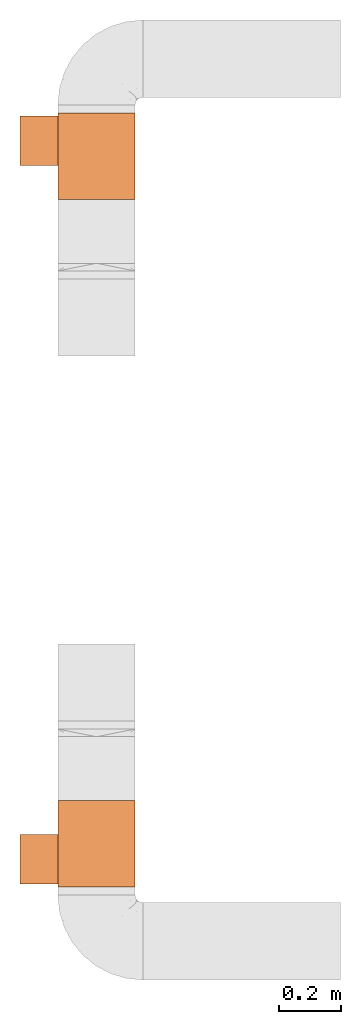
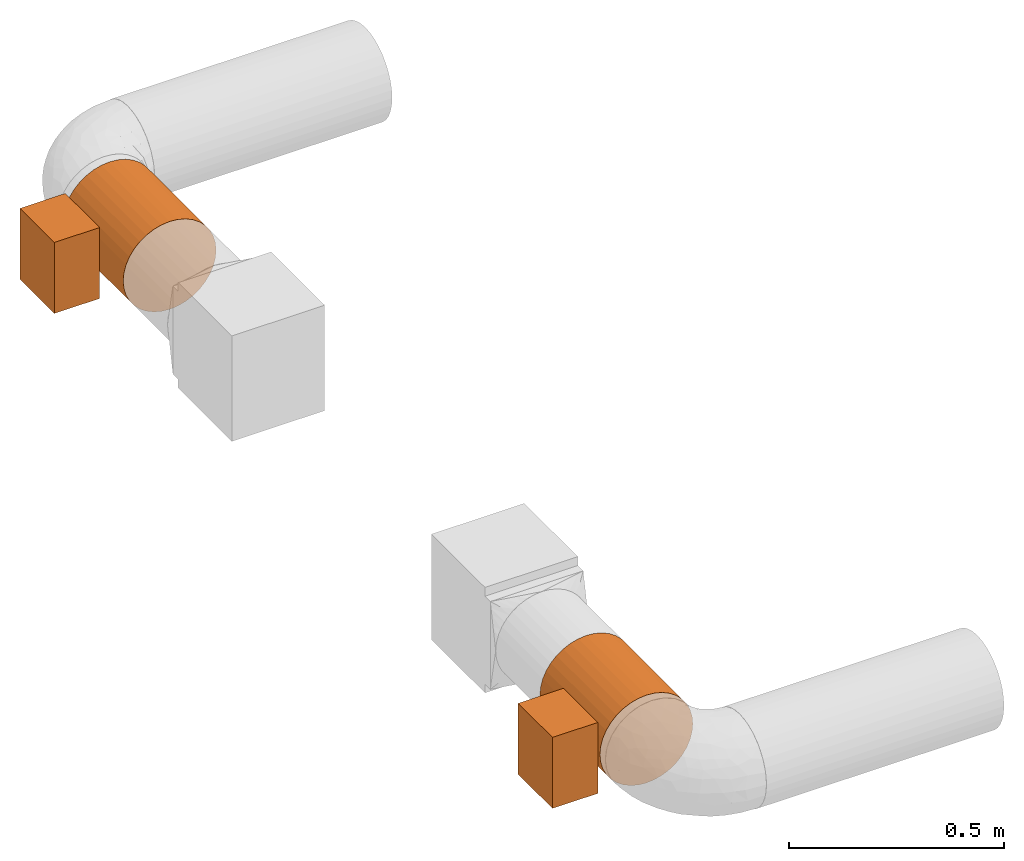
# One storey, part 4 of 4: 2 proxies.
"""IFC2X3 building model written with IfcOpenShell, lengths in millimetres."""

from ifc_helpers import new_model, entity, si_unit, converted_unit, derived_unit, direction, frame, frame_2d, origin, origin_2d_with_axis, place, context, subcontext, project, spatial, rectangle, circle, extrude, source, transform, mapped, type_object, type_shapes, element, save


model = new_model("IFC2X3")

# Units and contexts
model_context = context("Model", 3, precision=0.01, world=origin(), true_north=direction((6.12303176911189e-17, 1.0)))
body_context = subcontext(model_context, "Body", "Model", "MODEL_VIEW")
ifc_project = project(units=[si_unit("LENGTHUNIT", "METRE", prefix="MILLI"), si_unit("AREAUNIT", "SQUARE_METRE"), si_unit("VOLUMEUNIT", "CUBIC_METRE"), converted_unit("PLANEANGLEUNIT", "DEGREE", entity("IfcRatioMeasure", 0.0174532925199433), si_unit("PLANEANGLEUNIT", "RADIAN"), dimensions=[0, 0, 0, 0, 0, 0, 0]), si_unit("MASSUNIT", "GRAM", prefix="KILO"), derived_unit("MASSDENSITYUNIT", [(si_unit("MASSUNIT", "GRAM", prefix="KILO"), 1), (si_unit("LENGTHUNIT", "METRE"), -3)]), si_unit("TIMEUNIT", "SECOND"), si_unit("FREQUENCYUNIT", "HERTZ"), si_unit("THERMODYNAMICTEMPERATUREUNIT", "DEGREE_CELSIUS"), derived_unit("THERMALTRANSMITTANCEUNIT", [(si_unit("MASSUNIT", "GRAM", prefix="KILO"), 1), (si_unit("THERMODYNAMICTEMPERATUREUNIT", "KELVIN"), -1), (si_unit("TIMEUNIT", "SECOND"), -3)]), derived_unit("VOLUMETRICFLOWRATEUNIT", [(si_unit("LENGTHUNIT", "METRE"), 3), (si_unit("TIMEUNIT", "SECOND"), -1)]), si_unit("ELECTRICCURRENTUNIT", "AMPERE"), si_unit("ELECTRICVOLTAGEUNIT", "VOLT"), si_unit("POWERUNIT", "WATT"), si_unit("FORCEUNIT", "NEWTON", prefix="KILO"), si_unit("ILLUMINANCEUNIT", "LUX"), si_unit("LUMINOUSFLUXUNIT", "LUMEN"), si_unit("LUMINOUSINTENSITYUNIT", "CANDELA"), derived_unit("USERDEFINED", [(si_unit("MASSUNIT", "GRAM", prefix="KILO"), -1), (si_unit("LENGTHUNIT", "METRE"), -2), (si_unit("TIMEUNIT", "SECOND"), 3), (si_unit("LUMINOUSFLUXUNIT", "LUMEN"), 1)]), derived_unit("LINEARVELOCITYUNIT", [(si_unit("LENGTHUNIT", "METRE"), 1), (si_unit("TIMEUNIT", "SECOND"), -1)]), si_unit("PRESSUREUNIT", "PASCAL"), derived_unit("USERDEFINED", [(si_unit("LENGTHUNIT", "METRE"), -2), (si_unit("MASSUNIT", "GRAM", prefix="KILO"), 1), (si_unit("TIMEUNIT", "SECOND"), -2)])], contexts=[model_context])

# Site, building, storey
site_placement = place(None, origin())
site = spatial("IfcSite", under=ifc_project, at=site_placement, CompositionType="ELEMENT")
building_placement = place(site_placement, origin())
building = spatial("IfcBuilding", under=site, at=building_placement, CompositionType="ELEMENT")
storey_placement = place(building_placement, frame((0.0, 0.0, 8000.0)))
storey = spatial("IfcBuildingStorey", under=building, at=storey_placement, Name="02 Level", CompositionType="ELEMENT", Elevation=8000.0)

# Proxies
building_element_proxy_type_1 = type_object("IfcBuildingElementProxyType", Name="WH25-250-1", PredefinedType="NOTDEFINED")
shared_shape_1 = source(origin(), body_context, "Body", "SweptSolid", [
    extrude(rectangle(XDim=202.0, YDim=160.0, at=origin_2d_with_axis()), frame((50.0, -16.0, 125.0), z_axis=(0.0, 0.0, 1.0), x_axis=(0.0, -1.0, 0.0)), (0.0, 0.0, 1.0), 122.0),
    extrude(circle(Radius=125.0, at=frame_2d((0.0, -2.01943071804073e-13), x_axis=(1.0, 0.0))), frame((-140.0, 0.0, 0.0), z_axis=(1.0, 0.0, 0.0), x_axis=(0.0, 1.0, 0.0)), (0.0, 0.0, 1.0), 280.0),
])
type_shapes(building_element_proxy_type_1, [shared_shape_1])
proxy_1_placement = place(storey_placement, frame((25195.9632723171, -69942.4616421939, 3510.0), z_axis=(-1.0, 0.0, 0.0), x_axis=(0.0, -1.0, 0.0)))
element("IfcBuildingElementProxy", 1, at=proxy_1_placement, inside=storey, type_object=building_element_proxy_type_1, Name="WH25-0001:WH25-250-1", ObjectType="WH25-0001:WH25-250-1", context=body_context, shape_type="MappedRepresentation", body=[
    mapped(shared_shape_1, transform((0.0, 0.0, 0.0), scale=1.0)),
])
building_element_proxy_type_2 = type_object("IfcBuildingElementProxyType", Name="WH25-250-1", PredefinedType="NOTDEFINED")
shared_shape_2 = source(origin(), body_context, "Body", "SweptSolid", [
    extrude(rectangle(XDim=160.0, YDim=202.0, at=origin_2d_with_axis()), frame((50.0, 16.0, 125.0)), (0.0, 0.0, 1.0), 122.0),
    extrude(circle(Radius=125.0, at=frame_2d((0.0, -1.74187496188444e-13), x_axis=(1.0, 0.0))), frame((-140.0, 0.0, 0.0), z_axis=(1.0, 0.0, 0.0), x_axis=(0.0, -1.0, 0.0)), (0.0, 0.0, 1.0), 280.0),
])
type_shapes(building_element_proxy_type_2, [shared_shape_2])
proxy_2_placement = place(storey_placement, frame((25195.9632723171, -67720.0175280859, 3510.0), z_axis=(-1.0, 0.0, 0.0), x_axis=(0.0, 1.0, 0.0)))
element("IfcBuildingElementProxy", 2, at=proxy_2_placement, inside=storey, type_object=building_element_proxy_type_2, Name="WH25-0001:WH25-250-1", ObjectType="WH25-0001:WH25-250-1", context=body_context, shape_type="MappedRepresentation", body=[
    mapped(shared_shape_2, transform((0.0, 0.0, 0.0), scale=1.0)),
])

save(model, "model.ifc")
